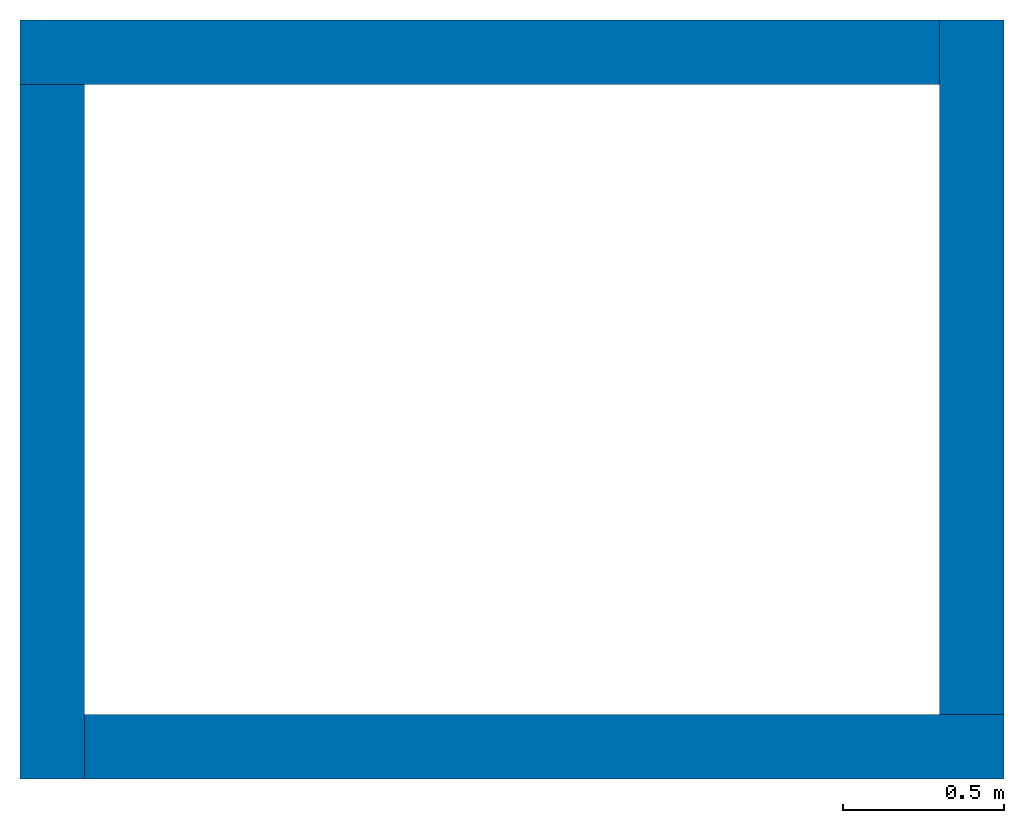
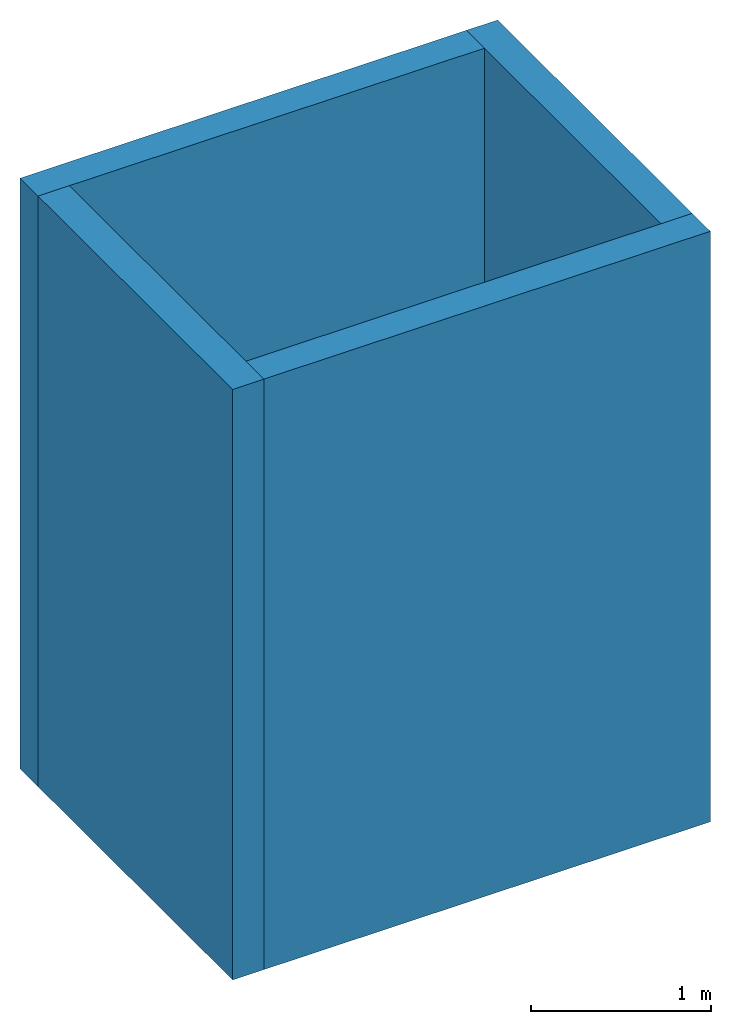
# One storey: 4 walls.
"""IFC2X3 building model written with IfcOpenShell, lengths in millimetres."""

from ifc_helpers import new_model, entity, si_unit, converted_unit, derived_unit, direction, frame, frame_2d, origin, place, context, subcontext, project, spatial, rectangle, extrude, material, layer, layer_set, layer_usage, type_object, element, save


model = new_model("IFC2X3")

# Units and contexts
model_context = context("Model", 3, precision=0.01, world=origin(), true_north=direction((6.12303176911189e-17, 1.0)))
context_of_model = context(None, 3, precision=0.01, world=origin(), true_north=direction((6.12303176911189e-17, 1.0)))
body_context = subcontext(model_context, "Body", "Model", "MODEL_VIEW")
ifc_project = project(units=[si_unit("LENGTHUNIT", "METRE", prefix="MILLI"), si_unit("AREAUNIT", "SQUARE_METRE"), si_unit("VOLUMEUNIT", "CUBIC_METRE"), converted_unit("PLANEANGLEUNIT", "DEGREE", entity("IfcRatioMeasure", 0.0174532925199433), si_unit("PLANEANGLEUNIT", "RADIAN"), dimensions=[0, 0, 0, 0, 0, 0, 0]), si_unit("MASSUNIT", "GRAM", prefix="KILO"), derived_unit("MASSDENSITYUNIT", [(si_unit("MASSUNIT", "GRAM", prefix="KILO"), 1), (si_unit("LENGTHUNIT", "METRE"), -3)]), si_unit("TIMEUNIT", "SECOND"), si_unit("FREQUENCYUNIT", "HERTZ"), si_unit("THERMODYNAMICTEMPERATUREUNIT", "DEGREE_CELSIUS"), derived_unit("THERMALTRANSMITTANCEUNIT", [(si_unit("MASSUNIT", "GRAM", prefix="KILO"), 1), (si_unit("THERMODYNAMICTEMPERATUREUNIT", "KELVIN"), -1), (si_unit("TIMEUNIT", "SECOND"), -3)]), derived_unit("VOLUMETRICFLOWRATEUNIT", [(si_unit("LENGTHUNIT", "METRE"), 3), (si_unit("TIMEUNIT", "SECOND"), -1)]), si_unit("ELECTRICCURRENTUNIT", "AMPERE"), si_unit("ELECTRICVOLTAGEUNIT", "VOLT"), si_unit("POWERUNIT", "WATT"), si_unit("FORCEUNIT", "NEWTON", prefix="KILO"), si_unit("ILLUMINANCEUNIT", "LUX"), si_unit("LUMINOUSFLUXUNIT", "LUMEN"), si_unit("LUMINOUSINTENSITYUNIT", "CANDELA"), derived_unit("USERDEFINED", [(si_unit("MASSUNIT", "GRAM", prefix="KILO"), -1), (si_unit("LENGTHUNIT", "METRE"), -2), (si_unit("TIMEUNIT", "SECOND"), 3), (si_unit("LUMINOUSFLUXUNIT", "LUMEN"), 1)]), derived_unit("LINEARVELOCITYUNIT", [(si_unit("LENGTHUNIT", "METRE"), 1), (si_unit("TIMEUNIT", "SECOND"), -1)]), si_unit("PRESSUREUNIT", "PASCAL"), derived_unit("USERDEFINED", [(si_unit("LENGTHUNIT", "METRE"), -2), (si_unit("MASSUNIT", "GRAM", prefix="KILO"), 1), (si_unit("TIMEUNIT", "SECOND"), -2)])], contexts=[model_context, context_of_model])

# Site, building, storey
site_placement = place(None, origin())
site = spatial("IfcSite", under=ifc_project, at=site_placement, CompositionType="ELEMENT")
building_placement = place(site_placement, origin())
building = spatial("IfcBuilding", under=site, at=building_placement, CompositionType="ELEMENT")
storey_placement = place(building_placement, origin())
storey = spatial("IfcBuildingStorey", under=building, at=storey_placement, Name="Level 1", CompositionType="ELEMENT", Elevation=0.0)

# Walls
ifc_material = material(Name="Default Wall")
ifc_layer = layer(ifc_material, 200.0)
ifc_layer_set = layer_set([ifc_layer], Name="Basic Wall:Wall 1")
ifc_layer_usage_1 = layer_usage(ifc_layer_set, "AXIS2", "NEGATIVE", 100.0)
wall_type = type_object("IfcWallType", Name="Basic Wall:Wall 1", PredefinedType="STANDARD", material=ifc_layer_set)
wall_1_placement = place(storey_placement, frame((524.569707401033, 3115.31841652324, 0.0)))
element("IfcWallStandardCase", 1, at=wall_1_placement, inside=storey, type_object=wall_type, material=ifc_layer_usage_1, Name="Basic Wall:Wall 1:2474", ObjectType="Basic Wall:Wall 1", context=body_context, shape_type="SweptSolid", body=[
    extrude(rectangle(XDim=2860.0, YDim=200.0, at=frame_2d((1430.0, 0.0), x_axis=(-1.0, 0.0))), origin(), (0.0, 0.0, 1.0), 4000.0),
])
ifc_layer_usage_2 = layer_usage(ifc_layer_set, "AXIS2", "NEGATIVE", 100.0)
wall_2_placement = place(storey_placement, frame((624.569707401033, 855.318416523237, 0.0), z_axis=(0.0, 0.0, 1.0), x_axis=(0.0, 1.0, 0.0)))
element("IfcWallStandardCase", 2, at=wall_2_placement, inside=storey, type_object=wall_type, material=ifc_layer_usage_2, Name="Basic Wall:Wall 1:2475", ObjectType="Basic Wall:Wall 1", context=body_context, shape_type="SweptSolid", body=[
    extrude(rectangle(XDim=2160.0, YDim=200.0, at=frame_2d((1080.0, 0.0), x_axis=(-1.0, 0.0))), origin(), (0.0, 0.0, 1.0), 4000.0),
])
ifc_layer_usage_3 = layer_usage(ifc_layer_set, "AXIS2", "NEGATIVE", 100.0)
wall_3_placement = place(storey_placement, frame((3584.56970740103, 955.318416523237, 0.0), z_axis=(0.0, 0.0, 1.0), x_axis=(-1.0, 0.0, 0.0)))
element("IfcWallStandardCase", 3, at=wall_3_placement, inside=storey, type_object=wall_type, material=ifc_layer_usage_3, Name="Basic Wall:Wall 1:2476", ObjectType="Basic Wall:Wall 1", context=body_context, shape_type="SweptSolid", body=[
    extrude(rectangle(XDim=2860.0, YDim=200.0, at=frame_2d((1430.0, 0.0), x_axis=(-1.0, 0.0))), origin(), (0.0, 0.0, 1.0), 4000.0),
])
ifc_layer_usage_4 = layer_usage(ifc_layer_set, "AXIS2", "NEGATIVE", 100.0)
wall_4_placement = place(storey_placement, frame((3484.56970740103, 3215.31841652324, 0.0), z_axis=(0.0, 0.0, 1.0), x_axis=(0.0, -1.0, 0.0)))
element("IfcWallStandardCase", 4, at=wall_4_placement, inside=storey, type_object=wall_type, material=ifc_layer_usage_4, Name="Basic Wall:Wall 1:2477", ObjectType="Basic Wall:Wall 1", context=body_context, shape_type="SweptSolid", body=[
    extrude(rectangle(XDim=2160.0, YDim=200.0, at=frame_2d((1080.0, 0.0), x_axis=(-1.0, 0.0))), origin(), (0.0, 0.0, 1.0), 4000.0),
])

save(model, "model.ifc")
